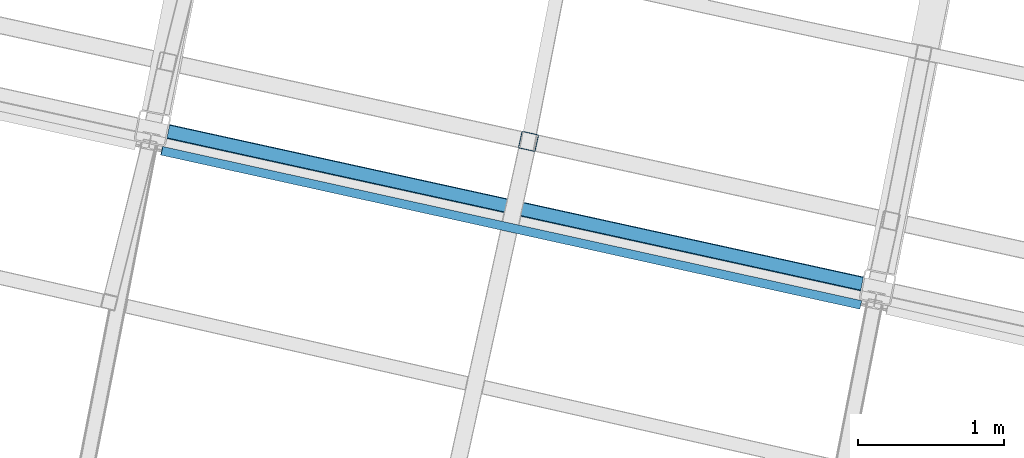
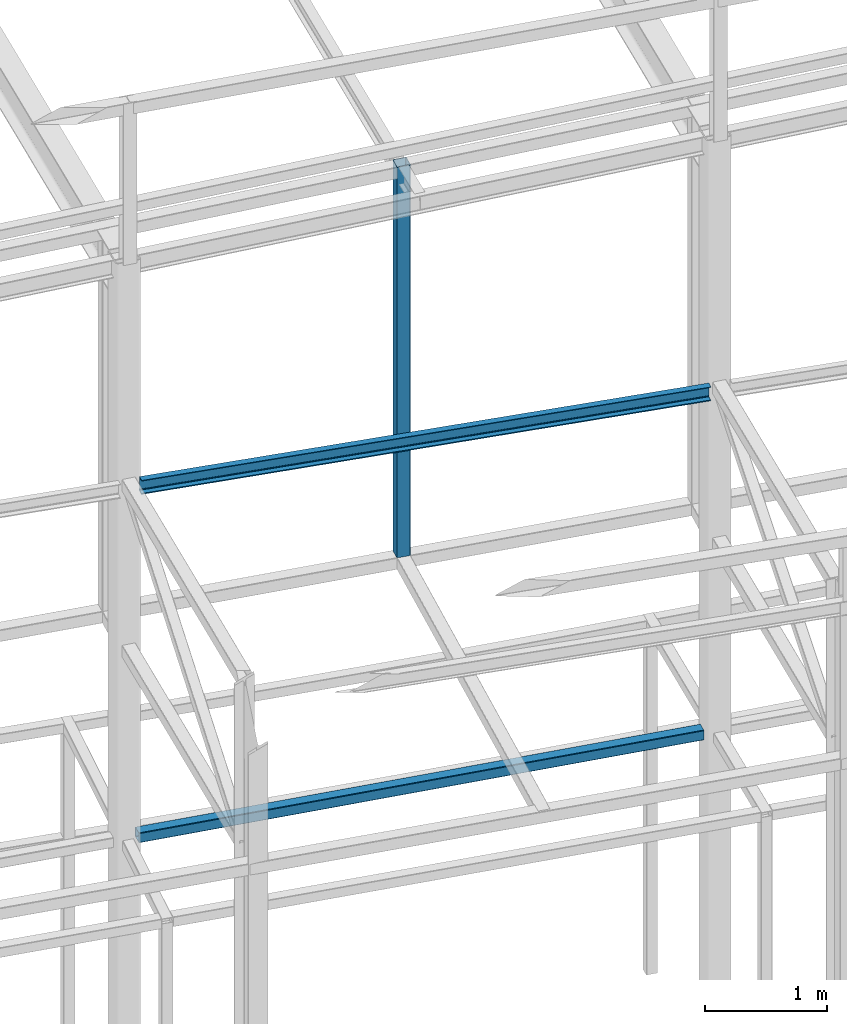
# One storey, part 26 of 215: 3 beams, 3 elements without a shape of their own.
"""IFC2X3 building model written with IfcOpenShell, lengths in millimetres."""

from ifc_helpers import new_model, si_unit, frame, origin_with_axes, origin_2d_with_axis, place, context, subcontext, project, spatial, hollow_rectangle, u_section, extrude, clip, halfspace, material, type_object, element, aggregate, save


model = new_model("IFC2X3")

# Units and contexts
model_context = context("Model", 3, precision=1e-05, world=origin_with_axes())
body_context = subcontext(model_context, "Body", "Model", "MODEL_VIEW")
ifc_project = project(units=[si_unit("LENGTHUNIT", "METRE", prefix="MILLI"), si_unit("AREAUNIT", "SQUARE_METRE"), si_unit("VOLUMEUNIT", "CUBIC_METRE"), si_unit("MASSUNIT", "GRAM", prefix="KILO"), si_unit("TIMEUNIT", "SECOND"), si_unit("PLANEANGLEUNIT", "RADIAN"), si_unit("SOLIDANGLEUNIT", "STERADIAN"), si_unit("THERMODYNAMICTEMPERATUREUNIT", "DEGREE_CELSIUS"), si_unit("LUMINOUSINTENSITYUNIT", "LUMEN")], contexts=[model_context])

# Site, building, storey
site_placement = place(None, origin_with_axes())
site = spatial("IfcSite", under=ifc_project, at=site_placement, CompositionType="ELEMENT")
building_placement = place(site_placement, origin_with_axes())
building = spatial("IfcBuilding", under=site, at=building_placement, Name="Undefined", CompositionType="ELEMENT")
storey_placement = place(building_placement, origin_with_axes())
storey = spatial("IfcBuildingStorey", under=building, at=storey_placement, Name="Undefined", CompositionType="ELEMENT", Elevation=0.0)

# Assembly, beam
assembly_1_placement = place(storey_placement, origin_with_axes())
assembly_1 = element("IfcElementAssembly", 1, at=assembly_1_placement, inside=storey, Name="Steel Assembly", AssemblyPlace="NOTDEFINED", PredefinedType="RIGID_FRAME")
ifc_material = material(Name="STEEL/S275JR")
beam_type_1 = type_object("IfcBeamType", PredefinedType="NOTDEFINED")
beam_1_placement = place(assembly_1_placement, frame((54987.6815549913, 8009.24817157012, 6760.00000147687), z_axis=(0.214484663892396, 0.976727356509976, 0.0), x_axis=(0.976727356509977, -0.214484663892393, 0.0)))
beam_1 = element("IfcBeam", 2, at=beam_1_placement, type_object=beam_type_1, material=ifc_material, Name="POUTRE", context=body_context, shape_type="Clipping", body=[
    clip(clip(extrude(hollow_rectangle(XDim=100.0, YDim=100.0, WallThickness=4.0, InnerFilletRadius=4.0, OuterFilletRadius=8.0, at=origin_2d_with_axis()), frame((5018.45293337742, 0.0, -3.63797880709171e-12), z_axis=(-1.0, 0.0, 0.0), x_axis=(-6.93889390390723e-18, -1.0, -3.46944695195361e-18)), (0.0, 0.0, 1.0), 4948.6), halfspace(frame((4980.87030910013, -50.0, -113.165216643836), z_axis=(0.999733029085594, 0.0, 0.0231056390377605), x_axis=(-6.93889390390723e-18, -1.0, -3.46944695195361e-18)), False)), halfspace(frame((111.661522913309, -50.0, -71.7256375611032), z_axis=(0.999733029085594, 0.0, 0.0231056390377605), x_axis=(-6.93889390390723e-18, -1.0, -3.46944695195361e-18)), True)),
])
aggregate(assembly_1, [beam_1])

assembly_2_placement = place(storey_placement, origin_with_axes())
assembly_2 = element("IfcElementAssembly", 3, at=assembly_2_placement, inside=storey, Name="Steel Assembly", AssemblyPlace="NOTDEFINED", PredefinedType="RIGID_FRAME")
beam_type_2 = type_object("IfcBeamType", PredefinedType="NOTDEFINED")
beam_2_placement = place(assembly_2_placement, frame((57564.3654419107, 7918.20490791676, 12681.0307911867), z_axis=(-0.214538758981639, -0.97671547591641, 0.0), x_axis=(0.0, 0.0, -1.0)))
beam_2 = element("IfcBeam", 4, at=beam_2_placement, type_object=beam_type_2, material=ifc_material, Name="LISSE", context=body_context, shape_type="SweptSolid", body=[
    extrude(hollow_rectangle(XDim=120.0, YDim=120.0, WallThickness=5.0, InnerFilletRadius=5.0, OuterFilletRadius=10.0, at=origin_2d_with_axis()), frame((3915.02998237898, 7.27595761418343e-12, -6.17327033869532e-21), z_axis=(-1.0, 0.0, 0.0), x_axis=(-6.93889390390723e-18, -1.0, -3.46944695195361e-18)), (0.0, 0.0, 1.0), 3915.0),
])
aggregate(assembly_2, [beam_2])

assembly_3_placement = place(storey_placement, origin_with_axes())
assembly_3 = element("IfcElementAssembly", 5, at=assembly_3_placement, inside=storey, Name="Steel Assembly", AssemblyPlace="NOTDEFINED", PredefinedType="RIGID_FRAME")
beam_type_3 = type_object("IfcBeamType", Name="UPN140", PredefinedType="NOTDEFINED")
beam_3_placement = place(assembly_3_placement, frame((59840.1133730018, 6797.58035416033, 10260.3205733168), z_axis=(-0.0195417610019211, 0.00430897700042411, -0.999799756098267), x_axis=(-0.976339712184534, 0.215314466040696, 0.0200111750037821)))
beam_3 = element("IfcBeam", 6, at=beam_3_placement, type_object=beam_type_3, material=ifc_material, ObjectType="UPN140", context=body_context, shape_type="SweptSolid", body=[
    extrude(u_section(Depth=140.0, FlangeWidth=60.0, WebThickness=7.0, FlangeThickness=10.0, FilletRadius=10.0, EdgeRadius=5.0, FlangeSlope=0.0798299857122373, at=origin_2d_with_axis()), frame((4905.81514188096, 1.77172547464461e-14, -1.80196893815501e-12), z_axis=(-1.0, 0.0, 0.0), x_axis=(-6.93889390390723e-18, -1.0, -3.46944695195361e-18)), (0.0, 0.0, 1.0), 4905.8),
])
aggregate(assembly_3, [beam_3])

save(model, "model.ifc")
